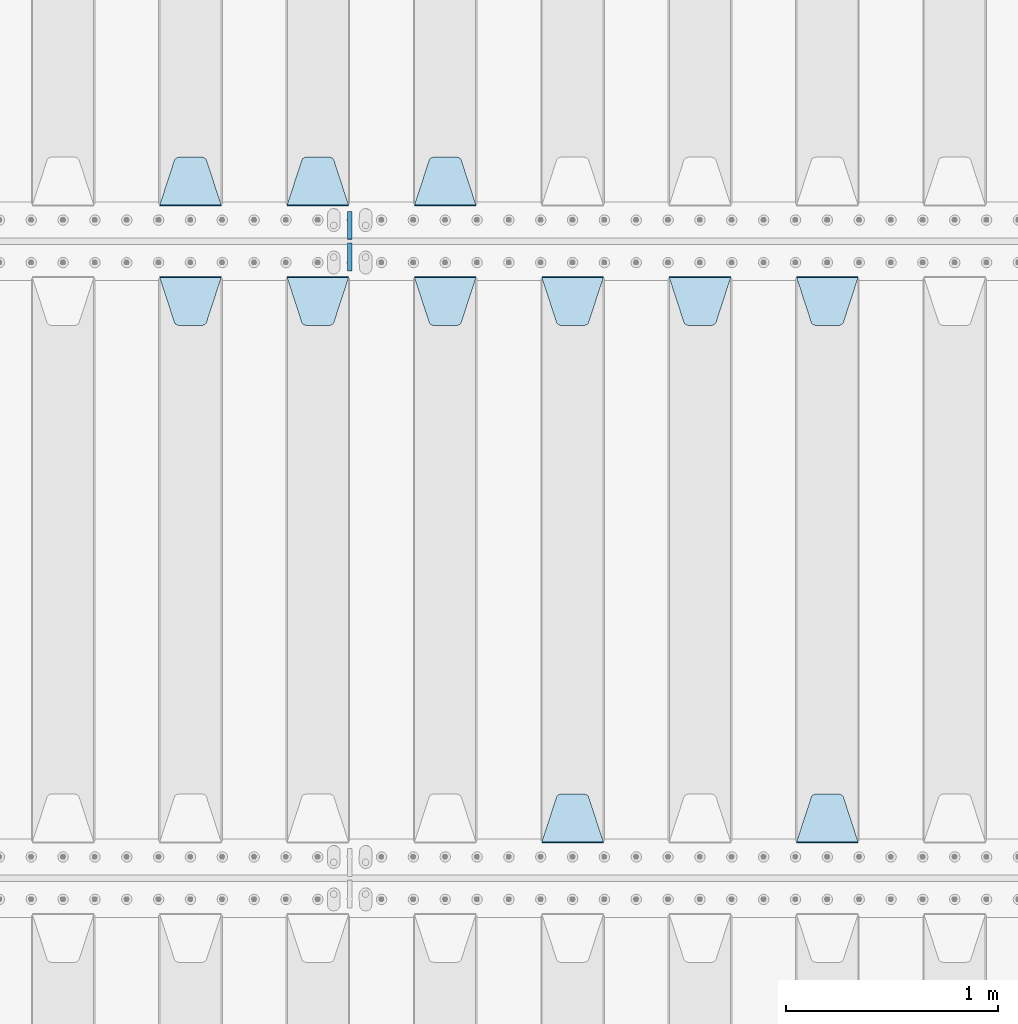
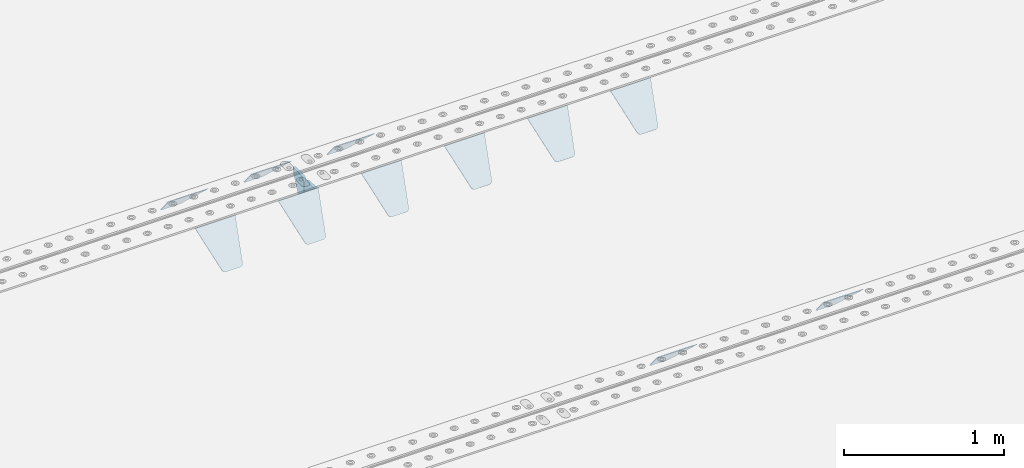
# One storey, part 196 of 240: 13 plates.
"""IFC2X3 building model written with IfcOpenShell, lengths in millimetres."""

from ifc_helpers import new_model, si_unit, frame, origin_with_axes, place, context, subcontext, project, spatial, faceted_brep, material, type_object, element, save


model = new_model("IFC2X3")

# Units and contexts
model_context = context("Model", 3, precision=1e-05, world=origin_with_axes())
body_context = subcontext(model_context, "Body", "Model", "MODEL_VIEW")
ifc_project = project(units=[si_unit("LENGTHUNIT", "METRE", prefix="MILLI"), si_unit("AREAUNIT", "SQUARE_METRE"), si_unit("VOLUMEUNIT", "CUBIC_METRE"), si_unit("MASSUNIT", "GRAM", prefix="KILO"), si_unit("TIMEUNIT", "SECOND"), si_unit("PLANEANGLEUNIT", "RADIAN"), si_unit("SOLIDANGLEUNIT", "STERADIAN"), si_unit("THERMODYNAMICTEMPERATUREUNIT", "DEGREE_CELSIUS"), si_unit("LUMINOUSINTENSITYUNIT", "LUMEN")], contexts=[model_context])

# Site, building, storey
site_placement = place(None, origin_with_axes())
site = spatial("IfcSite", under=ifc_project, at=site_placement, CompositionType="ELEMENT")
building_placement = place(site_placement, origin_with_axes())
building = spatial("IfcBuilding", under=site, at=building_placement, Name="Standard", CompositionType="ELEMENT")
storey_placement = place(building_placement, origin_with_axes())
storey = spatial("IfcBuildingStorey", under=building, at=storey_placement, Name="Undefined", CompositionType="ELEMENT", Elevation=0.0)

# Plates
ifc_material = material(Name="STEEL/S355N")
plate_type_1 = type_object("IfcPlateType", PredefinedType="NOTDEFINED")
plate_1_placement = place(storey_placement, frame((47195.0, 30168.232233047, -1.76776695296758), z_axis=(0.0, 0.707106781186547, -0.707106781186548), x_axis=(-1.0, 0.0, 0.0)))
element("IfcPlate", 1, at=plate_1_placement, inside=storey, type_object=plate_type_1, material=ifc_material, context=body_context, shape_type="Brep", body=[
    faceted_brep([(0.0, -2.5, 0.0), (69.345504679477, -2.50000000000364, 300.171731424827), (69.345504679477, 2.49999999999636, 300.171731424827), (0.0, 2.5, 0.0), (70.927406119954, -2.50000000000364, 304.897442415397), (70.927406119954, 2.49999999999636, 304.897442415397), (73.3818627772271, -2.50000000000728, 309.234538108525), (73.3818627772271, 2.49999999999636, 309.234538108529), (76.6187032999587, -2.50000000000728, 313.023683126099), (76.6187032999587, 2.49999999999636, 313.023683126103), (80.5190132705029, -2.50000000000364, 316.125672595368), (80.5190132705029, 2.49999999999636, 316.125672595368), (84.9395038596849, -2.50000000000364, 318.426546230472), (84.9395038596849, 2.49999999999636, 318.426546230472), (89.7177759439219, -2.5, 319.841774983277), (89.7177759439219, 2.49999999999636, 319.841774983273), (94.6782862926484, -2.50000000000364, 320.319366455074), (94.6782862926484, 2.49999999999636, 320.319366455074), (195.321713707352, -2.50000000000364, 320.319366455074), (195.321713707352, 2.49999999999636, 320.319366455074), (200.282224056078, -2.50000000000364, 319.841774983273), (200.282224056078, 2.49999999999636, 319.841774983273), (205.060496140315, -2.50000000000364, 318.426546230472), (205.060496140315, 2.49999999999636, 318.426546230472), (209.480986729497, -2.50000000000364, 316.125672595368), (209.480986729497, 2.49999999999636, 316.125672595368), (213.381296700041, -2.50000000000728, 313.023683126099), (213.381296700041, 2.49999999999272, 313.023683126099), (216.618137222766, -2.50000000000364, 309.234538108522), (216.618137222766, 2.49999999999636, 309.234538108522), (219.072593880039, -2.50000000000364, 304.897442415397), (219.072593880039, 2.49999999999636, 304.897442415397), (220.654495320523, -2.50000000000364, 300.171731424827), (220.654495320523, 2.49999999999636, 300.171731424827), (290.0, -2.50000000000364, -3.63797880709171e-12), (290.0, 2.49999999999636, -3.63797880709171e-12)], [[[0, 1, 2, 3]], [[1, 4, 5, 2]], [[4, 6, 7, 5]], [[6, 8, 9, 7]], [[8, 10, 11, 9]], [[10, 12, 13, 11]], [[12, 14, 15, 13]], [[14, 16, 17, 15]], [[16, 18, 19, 17]], [[18, 20, 21, 19]], [[20, 22, 23, 21]], [[22, 24, 25, 23]], [[24, 26, 27, 25]], [[26, 28, 29, 27]], [[28, 30, 31, 29]], [[30, 32, 33, 31]], [[32, 34, 35, 33]], [[34, 0, 3, 35]], [[5, 7, 9, 11, 13, 15, 17, 19, 21, 23, 25, 27, 29, 31, 33, 35, 3, 2]], [[34, 32, 30, 28, 26, 24, 22, 20, 18, 16, 14, 12, 10, 8, 6, 4, 1, 0]]]),
])
plate_2_placement = place(storey_placement, frame((46595.0, 30168.232233047, -1.76776695296758), z_axis=(0.0, 0.707106781186547, -0.707106781186548), x_axis=(-1.0, 0.0, 0.0)))
element("IfcPlate", 2, at=plate_2_placement, inside=storey, type_object=plate_type_1, material=ifc_material, context=body_context, shape_type="Brep", body=[
    faceted_brep([(0.0, -2.5, 0.0), (69.345504679477, -2.50000000000364, 300.171731424827), (69.345504679477, 2.49999999999636, 300.171731424827), (0.0, 2.5, 0.0), (70.927406119954, -2.50000000000364, 304.897442415397), (70.927406119954, 2.49999999999636, 304.897442415397), (73.3818627772271, -2.50000000000728, 309.234538108525), (73.3818627772271, 2.49999999999636, 309.234538108529), (76.6187032999587, -2.50000000000728, 313.023683126099), (76.6187032999587, 2.49999999999636, 313.023683126103), (80.5190132705029, -2.50000000000364, 316.125672595368), (80.5190132705029, 2.49999999999636, 316.125672595368), (84.9395038596849, -2.50000000000364, 318.426546230472), (84.9395038596849, 2.49999999999636, 318.426546230472), (89.7177759439219, -2.5, 319.841774983277), (89.7177759439219, 2.49999999999636, 319.841774983273), (94.6782862926484, -2.50000000000364, 320.319366455074), (94.6782862926484, 2.49999999999636, 320.319366455074), (195.321713707352, -2.50000000000364, 320.319366455074), (195.321713707352, 2.49999999999636, 320.319366455074), (200.282224056078, -2.50000000000364, 319.841774983273), (200.282224056078, 2.49999999999636, 319.841774983273), (205.060496140315, -2.50000000000364, 318.426546230472), (205.060496140315, 2.49999999999636, 318.426546230472), (209.480986729497, -2.50000000000364, 316.125672595368), (209.480986729497, 2.49999999999636, 316.125672595368), (213.381296700041, -2.50000000000728, 313.023683126099), (213.381296700041, 2.49999999999272, 313.023683126099), (216.618137222766, -2.50000000000364, 309.234538108522), (216.618137222766, 2.49999999999636, 309.234538108522), (219.072593880039, -2.50000000000364, 304.897442415397), (219.072593880039, 2.49999999999636, 304.897442415397), (220.654495320523, -2.50000000000364, 300.171731424827), (220.654495320523, 2.49999999999636, 300.171731424827), (290.0, -2.50000000000364, -3.63797880709171e-12), (290.0, 2.49999999999636, -3.63797880709171e-12)], [[[0, 1, 2, 3]], [[1, 4, 5, 2]], [[4, 6, 7, 5]], [[6, 8, 9, 7]], [[8, 10, 11, 9]], [[10, 12, 13, 11]], [[12, 14, 15, 13]], [[14, 16, 17, 15]], [[16, 18, 19, 17]], [[18, 20, 21, 19]], [[20, 22, 23, 21]], [[22, 24, 25, 23]], [[24, 26, 27, 25]], [[26, 28, 29, 27]], [[28, 30, 31, 29]], [[30, 32, 33, 31]], [[32, 34, 35, 33]], [[34, 0, 3, 35]], [[5, 7, 9, 11, 13, 15, 17, 19, 21, 23, 25, 27, 29, 31, 33, 35, 3, 2]], [[34, 32, 30, 28, 26, 24, 22, 20, 18, 16, 14, 12, 10, 8, 6, 4, 1, 0]]]),
])
plate_3_placement = place(storey_placement, frame((45995.0, 30168.232233047, -1.76776695296758), z_axis=(0.0, 0.707106781186547, -0.707106781186548), x_axis=(-1.0, 0.0, 0.0)))
element("IfcPlate", 3, at=plate_3_placement, inside=storey, type_object=plate_type_1, material=ifc_material, context=body_context, shape_type="Brep", body=[
    faceted_brep([(0.0, -2.5, 0.0), (69.345504679477, -2.50000000000364, 300.171731424827), (69.345504679477, 2.49999999999636, 300.171731424827), (0.0, 2.5, 0.0), (70.927406119954, -2.50000000000364, 304.897442415397), (70.927406119954, 2.49999999999636, 304.897442415397), (73.3818627772271, -2.50000000000728, 309.234538108525), (73.3818627772271, 2.49999999999636, 309.234538108529), (76.6187032999587, -2.50000000000728, 313.023683126099), (76.6187032999587, 2.49999999999636, 313.023683126103), (80.5190132705029, -2.50000000000364, 316.125672595368), (80.5190132705029, 2.49999999999636, 316.125672595368), (84.9395038596849, -2.50000000000364, 318.426546230472), (84.9395038596849, 2.49999999999636, 318.426546230472), (89.7177759439219, -2.5, 319.841774983277), (89.7177759439219, 2.49999999999636, 319.841774983273), (94.6782862926484, -2.50000000000364, 320.319366455074), (94.6782862926484, 2.49999999999636, 320.319366455074), (195.321713707352, -2.50000000000364, 320.319366455074), (195.321713707352, 2.49999999999636, 320.319366455074), (200.282224056078, -2.50000000000364, 319.841774983273), (200.282224056078, 2.49999999999636, 319.841774983273), (205.060496140315, -2.50000000000364, 318.426546230472), (205.060496140315, 2.49999999999636, 318.426546230472), (209.480986729497, -2.50000000000364, 316.125672595368), (209.480986729497, 2.49999999999636, 316.125672595368), (213.381296700041, -2.50000000000728, 313.023683126099), (213.381296700041, 2.49999999999272, 313.023683126099), (216.618137222766, -2.50000000000364, 309.234538108522), (216.618137222766, 2.49999999999636, 309.234538108522), (219.072593880039, -2.50000000000364, 304.897442415397), (219.072593880039, 2.49999999999636, 304.897442415397), (220.654495320523, -2.50000000000364, 300.171731424827), (220.654495320523, 2.49999999999636, 300.171731424827), (290.0, -2.50000000000364, -3.63797880709171e-12), (290.0, 2.49999999999636, -3.63797880709171e-12)], [[[0, 1, 2, 3]], [[1, 4, 5, 2]], [[4, 6, 7, 5]], [[6, 8, 9, 7]], [[8, 10, 11, 9]], [[10, 12, 13, 11]], [[12, 14, 15, 13]], [[14, 16, 17, 15]], [[16, 18, 19, 17]], [[18, 20, 21, 19]], [[20, 22, 23, 21]], [[22, 24, 25, 23]], [[24, 26, 27, 25]], [[26, 28, 29, 27]], [[28, 30, 31, 29]], [[30, 32, 33, 31]], [[32, 34, 35, 33]], [[34, 0, 3, 35]], [[5, 7, 9, 11, 13, 15, 17, 19, 21, 23, 25, 27, 29, 31, 33, 35, 3, 2]], [[34, 32, 30, 28, 26, 24, 22, 20, 18, 16, 14, 12, 10, 8, 6, 4, 1, 0]]]),
])
plate_4_placement = place(storey_placement, frame((48705.0, 29831.767766956, -1.76776695296758), z_axis=(0.0, -0.707106781186547, -0.707106781186548), x_axis=(1.0, 0.0, 0.0)))
element("IfcPlate", 4, at=plate_4_placement, inside=storey, type_object=plate_type_1, material=ifc_material, context=body_context, shape_type="Brep", body=[
    faceted_brep([(0.0, -2.5, 0.0), (69.345504679477, -2.50000000000364, 300.171731424827), (69.345504679477, 2.49999999999636, 300.171731424827), (0.0, 2.5, 0.0), (70.927406119954, -2.50000000000364, 304.897442415397), (70.927406119954, 2.49999999999636, 304.897442415397), (73.3818627772271, -2.50000000000728, 309.234538108525), (73.3818627772271, 2.49999999999636, 309.234538108529), (76.6187032999587, -2.50000000000728, 313.023683126099), (76.6187032999587, 2.49999999999636, 313.023683126103), (80.5190132705029, -2.50000000000364, 316.125672595368), (80.5190132705029, 2.49999999999636, 316.125672595368), (84.9395038596849, -2.50000000000364, 318.426546230472), (84.9395038596849, 2.49999999999636, 318.426546230472), (89.7177759439219, -2.5, 319.841774983277), (89.7177759439219, 2.49999999999636, 319.841774983273), (94.6782862926484, -2.50000000000364, 320.319366455074), (94.6782862926484, 2.49999999999636, 320.319366455074), (195.321713707352, -2.50000000000364, 320.319366455074), (195.321713707352, 2.49999999999636, 320.319366455074), (200.282224056078, -2.50000000000364, 319.841774983273), (200.282224056078, 2.49999999999636, 319.841774983273), (205.060496140315, -2.50000000000364, 318.426546230472), (205.060496140315, 2.49999999999636, 318.426546230472), (209.480986729497, -2.50000000000364, 316.125672595368), (209.480986729497, 2.49999999999636, 316.125672595368), (213.381296700041, -2.50000000000728, 313.023683126099), (213.381296700041, 2.49999999999272, 313.023683126099), (216.618137222766, -2.50000000000364, 309.234538108522), (216.618137222766, 2.49999999999636, 309.234538108522), (219.072593880039, -2.50000000000364, 304.897442415397), (219.072593880039, 2.49999999999636, 304.897442415397), (220.654495320523, -2.50000000000364, 300.171731424827), (220.654495320523, 2.49999999999636, 300.171731424827), (290.0, -2.50000000000364, -3.63797880709171e-12), (290.0, 2.49999999999636, -3.63797880709171e-12)], [[[0, 1, 2, 3]], [[1, 4, 5, 2]], [[4, 6, 7, 5]], [[6, 8, 9, 7]], [[8, 10, 11, 9]], [[10, 12, 13, 11]], [[12, 14, 15, 13]], [[14, 16, 17, 15]], [[16, 18, 19, 17]], [[18, 20, 21, 19]], [[20, 22, 23, 21]], [[22, 24, 25, 23]], [[24, 26, 27, 25]], [[26, 28, 29, 27]], [[28, 30, 31, 29]], [[30, 32, 33, 31]], [[32, 34, 35, 33]], [[34, 0, 3, 35]], [[5, 7, 9, 11, 13, 15, 17, 19, 21, 23, 25, 27, 29, 31, 33, 35, 3, 2]], [[34, 32, 30, 28, 26, 24, 22, 20, 18, 16, 14, 12, 10, 8, 6, 4, 1, 0]]]),
])
plate_5_placement = place(storey_placement, frame((48995.0, 27168.232233047, -1.76776695296758), z_axis=(0.0, 0.707106781186547, -0.707106781186548), x_axis=(-1.0, 0.0, 0.0)))
element("IfcPlate", 5, at=plate_5_placement, inside=storey, type_object=plate_type_1, material=ifc_material, context=body_context, shape_type="Brep", body=[
    faceted_brep([(0.0, -2.5, 0.0), (69.345504679477, -2.50000000000364, 300.171731424827), (69.345504679477, 2.49999999999636, 300.171731424827), (0.0, 2.5, 0.0), (70.927406119954, -2.50000000000364, 304.897442415397), (70.927406119954, 2.49999999999636, 304.897442415397), (73.3818627772271, -2.50000000000728, 309.234538108525), (73.3818627772271, 2.49999999999636, 309.234538108529), (76.6187032999587, -2.50000000000728, 313.023683126099), (76.6187032999587, 2.49999999999636, 313.023683126103), (80.5190132705029, -2.50000000000364, 316.125672595368), (80.5190132705029, 2.49999999999636, 316.125672595368), (84.9395038596849, -2.50000000000364, 318.426546230472), (84.9395038596849, 2.49999999999636, 318.426546230472), (89.7177759439219, -2.5, 319.841774983277), (89.7177759439219, 2.49999999999636, 319.841774983273), (94.6782862926484, -2.50000000000364, 320.319366455074), (94.6782862926484, 2.49999999999636, 320.319366455074), (195.321713707352, -2.50000000000364, 320.319366455074), (195.321713707352, 2.49999999999636, 320.319366455074), (200.282224056078, -2.50000000000364, 319.841774983273), (200.282224056078, 2.49999999999636, 319.841774983273), (205.060496140315, -2.50000000000364, 318.426546230472), (205.060496140315, 2.49999999999636, 318.426546230472), (209.480986729497, -2.50000000000364, 316.125672595368), (209.480986729497, 2.49999999999636, 316.125672595368), (213.381296700041, -2.50000000000728, 313.023683126099), (213.381296700041, 2.49999999999272, 313.023683126099), (216.618137222766, -2.50000000000364, 309.234538108522), (216.618137222766, 2.49999999999636, 309.234538108522), (219.072593880039, -2.50000000000364, 304.897442415397), (219.072593880039, 2.49999999999636, 304.897442415397), (220.654495320523, -2.50000000000364, 300.171731424827), (220.654495320523, 2.49999999999636, 300.171731424827), (290.0, -2.50000000000364, -3.63797880709171e-12), (290.0, 2.49999999999636, -3.63797880709171e-12)], [[[0, 1, 2, 3]], [[1, 4, 5, 2]], [[4, 6, 7, 5]], [[6, 8, 9, 7]], [[8, 10, 11, 9]], [[10, 12, 13, 11]], [[12, 14, 15, 13]], [[14, 16, 17, 15]], [[16, 18, 19, 17]], [[18, 20, 21, 19]], [[20, 22, 23, 21]], [[22, 24, 25, 23]], [[24, 26, 27, 25]], [[26, 28, 29, 27]], [[28, 30, 31, 29]], [[30, 32, 33, 31]], [[32, 34, 35, 33]], [[34, 0, 3, 35]], [[5, 7, 9, 11, 13, 15, 17, 19, 21, 23, 25, 27, 29, 31, 33, 35, 3, 2]], [[34, 32, 30, 28, 26, 24, 22, 20, 18, 16, 14, 12, 10, 8, 6, 4, 1, 0]]]),
])
plate_6_placement = place(storey_placement, frame((48105.0, 29831.767766956, -1.76776695296758), z_axis=(0.0, -0.707106781186547, -0.707106781186548), x_axis=(1.0, 0.0, 0.0)))
element("IfcPlate", 6, at=plate_6_placement, inside=storey, type_object=plate_type_1, material=ifc_material, context=body_context, shape_type="Brep", body=[
    faceted_brep([(0.0, -2.5, 0.0), (69.345504679477, -2.50000000000364, 300.171731424827), (69.345504679477, 2.49999999999636, 300.171731424827), (0.0, 2.5, 0.0), (70.927406119954, -2.50000000000364, 304.897442415397), (70.927406119954, 2.49999999999636, 304.897442415397), (73.3818627772271, -2.50000000000728, 309.234538108525), (73.3818627772271, 2.49999999999636, 309.234538108529), (76.6187032999587, -2.50000000000728, 313.023683126099), (76.6187032999587, 2.49999999999636, 313.023683126103), (80.5190132705029, -2.50000000000364, 316.125672595368), (80.5190132705029, 2.49999999999636, 316.125672595368), (84.9395038596849, -2.50000000000364, 318.426546230472), (84.9395038596849, 2.49999999999636, 318.426546230472), (89.7177759439219, -2.5, 319.841774983277), (89.7177759439219, 2.49999999999636, 319.841774983273), (94.6782862926484, -2.50000000000364, 320.319366455074), (94.6782862926484, 2.49999999999636, 320.319366455074), (195.321713707352, -2.50000000000364, 320.319366455074), (195.321713707352, 2.49999999999636, 320.319366455074), (200.282224056078, -2.50000000000364, 319.841774983273), (200.282224056078, 2.49999999999636, 319.841774983273), (205.060496140315, -2.50000000000364, 318.426546230472), (205.060496140315, 2.49999999999636, 318.426546230472), (209.480986729497, -2.50000000000364, 316.125672595368), (209.480986729497, 2.49999999999636, 316.125672595368), (213.381296700041, -2.50000000000728, 313.023683126099), (213.381296700041, 2.49999999999272, 313.023683126099), (216.618137222766, -2.50000000000364, 309.234538108522), (216.618137222766, 2.49999999999636, 309.234538108522), (219.072593880039, -2.50000000000364, 304.897442415397), (219.072593880039, 2.49999999999636, 304.897442415397), (220.654495320523, -2.50000000000364, 300.171731424827), (220.654495320523, 2.49999999999636, 300.171731424827), (290.0, -2.50000000000364, -3.63797880709171e-12), (290.0, 2.49999999999636, -3.63797880709171e-12)], [[[0, 1, 2, 3]], [[1, 4, 5, 2]], [[4, 6, 7, 5]], [[6, 8, 9, 7]], [[8, 10, 11, 9]], [[10, 12, 13, 11]], [[12, 14, 15, 13]], [[14, 16, 17, 15]], [[16, 18, 19, 17]], [[18, 20, 21, 19]], [[20, 22, 23, 21]], [[22, 24, 25, 23]], [[24, 26, 27, 25]], [[26, 28, 29, 27]], [[28, 30, 31, 29]], [[30, 32, 33, 31]], [[32, 34, 35, 33]], [[34, 0, 3, 35]], [[5, 7, 9, 11, 13, 15, 17, 19, 21, 23, 25, 27, 29, 31, 33, 35, 3, 2]], [[34, 32, 30, 28, 26, 24, 22, 20, 18, 16, 14, 12, 10, 8, 6, 4, 1, 0]]]),
])
plate_7_placement = place(storey_placement, frame((47505.0, 29831.767766956, -1.76776695296758), z_axis=(0.0, -0.707106781186547, -0.707106781186548), x_axis=(1.0, 0.0, 0.0)))
element("IfcPlate", 7, at=plate_7_placement, inside=storey, type_object=plate_type_1, material=ifc_material, context=body_context, shape_type="Brep", body=[
    faceted_brep([(0.0, -2.5, 0.0), (69.345504679477, -2.50000000000364, 300.171731424827), (69.345504679477, 2.49999999999636, 300.171731424827), (0.0, 2.5, 0.0), (70.927406119954, -2.50000000000364, 304.897442415397), (70.927406119954, 2.49999999999636, 304.897442415397), (73.3818627772271, -2.50000000000728, 309.234538108525), (73.3818627772271, 2.49999999999636, 309.234538108529), (76.6187032999587, -2.50000000000728, 313.023683126099), (76.6187032999587, 2.49999999999636, 313.023683126103), (80.5190132705029, -2.50000000000364, 316.125672595368), (80.5190132705029, 2.49999999999636, 316.125672595368), (84.9395038596849, -2.50000000000364, 318.426546230472), (84.9395038596849, 2.49999999999636, 318.426546230472), (89.7177759439219, -2.5, 319.841774983277), (89.7177759439219, 2.49999999999636, 319.841774983273), (94.6782862926484, -2.50000000000364, 320.319366455074), (94.6782862926484, 2.49999999999636, 320.319366455074), (195.321713707352, -2.50000000000364, 320.319366455074), (195.321713707352, 2.49999999999636, 320.319366455074), (200.282224056078, -2.50000000000364, 319.841774983273), (200.282224056078, 2.49999999999636, 319.841774983273), (205.060496140315, -2.50000000000364, 318.426546230472), (205.060496140315, 2.49999999999636, 318.426546230472), (209.480986729497, -2.50000000000364, 316.125672595368), (209.480986729497, 2.49999999999636, 316.125672595368), (213.381296700041, -2.50000000000728, 313.023683126099), (213.381296700041, 2.49999999999272, 313.023683126099), (216.618137222766, -2.50000000000364, 309.234538108522), (216.618137222766, 2.49999999999636, 309.234538108522), (219.072593880039, -2.50000000000364, 304.897442415397), (219.072593880039, 2.49999999999636, 304.897442415397), (220.654495320523, -2.50000000000364, 300.171731424827), (220.654495320523, 2.49999999999636, 300.171731424827), (290.0, -2.50000000000364, -3.63797880709171e-12), (290.0, 2.49999999999636, -3.63797880709171e-12)], [[[0, 1, 2, 3]], [[1, 4, 5, 2]], [[4, 6, 7, 5]], [[6, 8, 9, 7]], [[8, 10, 11, 9]], [[10, 12, 13, 11]], [[12, 14, 15, 13]], [[14, 16, 17, 15]], [[16, 18, 19, 17]], [[18, 20, 21, 19]], [[20, 22, 23, 21]], [[22, 24, 25, 23]], [[24, 26, 27, 25]], [[26, 28, 29, 27]], [[28, 30, 31, 29]], [[30, 32, 33, 31]], [[32, 34, 35, 33]], [[34, 0, 3, 35]], [[5, 7, 9, 11, 13, 15, 17, 19, 21, 23, 25, 27, 29, 31, 33, 35, 3, 2]], [[34, 32, 30, 28, 26, 24, 22, 20, 18, 16, 14, 12, 10, 8, 6, 4, 1, 0]]]),
])
plate_8_placement = place(storey_placement, frame((47795.0, 27168.232233047, -1.76776695296758), z_axis=(0.0, 0.707106781186547, -0.707106781186548), x_axis=(-1.0, 0.0, 0.0)))
element("IfcPlate", 8, at=plate_8_placement, inside=storey, type_object=plate_type_1, material=ifc_material, context=body_context, shape_type="Brep", body=[
    faceted_brep([(0.0, -2.5, 0.0), (69.345504679477, -2.50000000000364, 300.171731424827), (69.345504679477, 2.49999999999636, 300.171731424827), (0.0, 2.5, 0.0), (70.927406119954, -2.50000000000364, 304.897442415397), (70.927406119954, 2.49999999999636, 304.897442415397), (73.3818627772271, -2.50000000000728, 309.234538108525), (73.3818627772271, 2.49999999999636, 309.234538108529), (76.6187032999587, -2.50000000000728, 313.023683126099), (76.6187032999587, 2.49999999999636, 313.023683126103), (80.5190132705029, -2.50000000000364, 316.125672595368), (80.5190132705029, 2.49999999999636, 316.125672595368), (84.9395038596849, -2.50000000000364, 318.426546230472), (84.9395038596849, 2.49999999999636, 318.426546230472), (89.7177759439219, -2.5, 319.841774983277), (89.7177759439219, 2.49999999999636, 319.841774983273), (94.6782862926484, -2.50000000000364, 320.319366455074), (94.6782862926484, 2.49999999999636, 320.319366455074), (195.321713707352, -2.50000000000364, 320.319366455074), (195.321713707352, 2.49999999999636, 320.319366455074), (200.282224056078, -2.50000000000364, 319.841774983273), (200.282224056078, 2.49999999999636, 319.841774983273), (205.060496140315, -2.50000000000364, 318.426546230472), (205.060496140315, 2.49999999999636, 318.426546230472), (209.480986729497, -2.50000000000364, 316.125672595368), (209.480986729497, 2.49999999999636, 316.125672595368), (213.381296700041, -2.50000000000728, 313.023683126099), (213.381296700041, 2.49999999999272, 313.023683126099), (216.618137222766, -2.50000000000364, 309.234538108522), (216.618137222766, 2.49999999999636, 309.234538108522), (219.072593880039, -2.50000000000364, 304.897442415397), (219.072593880039, 2.49999999999636, 304.897442415397), (220.654495320523, -2.50000000000364, 300.171731424827), (220.654495320523, 2.49999999999636, 300.171731424827), (290.0, -2.50000000000364, -3.63797880709171e-12), (290.0, 2.49999999999636, -3.63797880709171e-12)], [[[0, 1, 2, 3]], [[1, 4, 5, 2]], [[4, 6, 7, 5]], [[6, 8, 9, 7]], [[8, 10, 11, 9]], [[10, 12, 13, 11]], [[12, 14, 15, 13]], [[14, 16, 17, 15]], [[16, 18, 19, 17]], [[18, 20, 21, 19]], [[20, 22, 23, 21]], [[22, 24, 25, 23]], [[24, 26, 27, 25]], [[26, 28, 29, 27]], [[28, 30, 31, 29]], [[30, 32, 33, 31]], [[32, 34, 35, 33]], [[34, 0, 3, 35]], [[5, 7, 9, 11, 13, 15, 17, 19, 21, 23, 25, 27, 29, 31, 33, 35, 3, 2]], [[34, 32, 30, 28, 26, 24, 22, 20, 18, 16, 14, 12, 10, 8, 6, 4, 1, 0]]]),
])
plate_9_placement = place(storey_placement, frame((46905.0, 29831.767766956, -1.76776695296758), z_axis=(0.0, -0.707106781186547, -0.707106781186548), x_axis=(1.0, 0.0, 0.0)))
element("IfcPlate", 9, at=plate_9_placement, inside=storey, type_object=plate_type_1, material=ifc_material, context=body_context, shape_type="Brep", body=[
    faceted_brep([(0.0, -2.5, 0.0), (69.345504679477, -2.50000000000364, 300.171731424827), (69.345504679477, 2.49999999999636, 300.171731424827), (0.0, 2.5, 0.0), (70.927406119954, -2.50000000000364, 304.897442415397), (70.927406119954, 2.49999999999636, 304.897442415397), (73.3818627772271, -2.50000000000728, 309.234538108525), (73.3818627772271, 2.49999999999636, 309.234538108529), (76.6187032999587, -2.50000000000728, 313.023683126099), (76.6187032999587, 2.49999999999636, 313.023683126103), (80.5190132705029, -2.50000000000364, 316.125672595368), (80.5190132705029, 2.49999999999636, 316.125672595368), (84.9395038596849, -2.50000000000364, 318.426546230472), (84.9395038596849, 2.49999999999636, 318.426546230472), (89.7177759439219, -2.5, 319.841774983277), (89.7177759439219, 2.49999999999636, 319.841774983273), (94.6782862926484, -2.50000000000364, 320.319366455074), (94.6782862926484, 2.49999999999636, 320.319366455074), (195.321713707352, -2.50000000000364, 320.319366455074), (195.321713707352, 2.49999999999636, 320.319366455074), (200.282224056078, -2.50000000000364, 319.841774983273), (200.282224056078, 2.49999999999636, 319.841774983273), (205.060496140315, -2.50000000000364, 318.426546230472), (205.060496140315, 2.49999999999636, 318.426546230472), (209.480986729497, -2.50000000000364, 316.125672595368), (209.480986729497, 2.49999999999636, 316.125672595368), (213.381296700041, -2.50000000000728, 313.023683126099), (213.381296700041, 2.49999999999272, 313.023683126099), (216.618137222766, -2.50000000000364, 309.234538108522), (216.618137222766, 2.49999999999636, 309.234538108522), (219.072593880039, -2.50000000000364, 304.897442415397), (219.072593880039, 2.49999999999636, 304.897442415397), (220.654495320523, -2.50000000000364, 300.171731424827), (220.654495320523, 2.49999999999636, 300.171731424827), (290.0, -2.50000000000364, -3.63797880709171e-12), (290.0, 2.49999999999636, -3.63797880709171e-12)], [[[0, 1, 2, 3]], [[1, 4, 5, 2]], [[4, 6, 7, 5]], [[6, 8, 9, 7]], [[8, 10, 11, 9]], [[10, 12, 13, 11]], [[12, 14, 15, 13]], [[14, 16, 17, 15]], [[16, 18, 19, 17]], [[18, 20, 21, 19]], [[20, 22, 23, 21]], [[22, 24, 25, 23]], [[24, 26, 27, 25]], [[26, 28, 29, 27]], [[28, 30, 31, 29]], [[30, 32, 33, 31]], [[32, 34, 35, 33]], [[34, 0, 3, 35]], [[5, 7, 9, 11, 13, 15, 17, 19, 21, 23, 25, 27, 29, 31, 33, 35, 3, 2]], [[34, 32, 30, 28, 26, 24, 22, 20, 18, 16, 14, 12, 10, 8, 6, 4, 1, 0]]]),
])
plate_10_placement = place(storey_placement, frame((46305.0, 29831.767766956, -1.76776695296758), z_axis=(0.0, -0.707106781186547, -0.707106781186548), x_axis=(1.0, 0.0, 0.0)))
element("IfcPlate", 10, at=plate_10_placement, inside=storey, type_object=plate_type_1, material=ifc_material, context=body_context, shape_type="Brep", body=[
    faceted_brep([(0.0, -2.5, 0.0), (69.345504679477, -2.50000000000364, 300.171731424827), (69.345504679477, 2.49999999999636, 300.171731424827), (0.0, 2.5, 0.0), (70.927406119954, -2.50000000000364, 304.897442415397), (70.927406119954, 2.49999999999636, 304.897442415397), (73.3818627772271, -2.50000000000728, 309.234538108525), (73.3818627772271, 2.49999999999636, 309.234538108529), (76.6187032999587, -2.50000000000728, 313.023683126099), (76.6187032999587, 2.49999999999636, 313.023683126103), (80.5190132705029, -2.50000000000364, 316.125672595368), (80.5190132705029, 2.49999999999636, 316.125672595368), (84.9395038596849, -2.50000000000364, 318.426546230472), (84.9395038596849, 2.49999999999636, 318.426546230472), (89.7177759439219, -2.5, 319.841774983277), (89.7177759439219, 2.49999999999636, 319.841774983273), (94.6782862926484, -2.50000000000364, 320.319366455074), (94.6782862926484, 2.49999999999636, 320.319366455074), (195.321713707352, -2.50000000000364, 320.319366455074), (195.321713707352, 2.49999999999636, 320.319366455074), (200.282224056078, -2.50000000000364, 319.841774983273), (200.282224056078, 2.49999999999636, 319.841774983273), (205.060496140315, -2.50000000000364, 318.426546230472), (205.060496140315, 2.49999999999636, 318.426546230472), (209.480986729497, -2.50000000000364, 316.125672595368), (209.480986729497, 2.49999999999636, 316.125672595368), (213.381296700041, -2.50000000000728, 313.023683126099), (213.381296700041, 2.49999999999272, 313.023683126099), (216.618137222766, -2.50000000000364, 309.234538108522), (216.618137222766, 2.49999999999636, 309.234538108522), (219.072593880039, -2.50000000000364, 304.897442415397), (219.072593880039, 2.49999999999636, 304.897442415397), (220.654495320523, -2.50000000000364, 300.171731424827), (220.654495320523, 2.49999999999636, 300.171731424827), (290.0, -2.50000000000364, -3.63797880709171e-12), (290.0, 2.49999999999636, -3.63797880709171e-12)], [[[0, 1, 2, 3]], [[1, 4, 5, 2]], [[4, 6, 7, 5]], [[6, 8, 9, 7]], [[8, 10, 11, 9]], [[10, 12, 13, 11]], [[12, 14, 15, 13]], [[14, 16, 17, 15]], [[16, 18, 19, 17]], [[18, 20, 21, 19]], [[20, 22, 23, 21]], [[22, 24, 25, 23]], [[24, 26, 27, 25]], [[26, 28, 29, 27]], [[28, 30, 31, 29]], [[30, 32, 33, 31]], [[32, 34, 35, 33]], [[34, 0, 3, 35]], [[5, 7, 9, 11, 13, 15, 17, 19, 21, 23, 25, 27, 29, 31, 33, 35, 3, 2]], [[34, 32, 30, 28, 26, 24, 22, 20, 18, 16, 14, 12, 10, 8, 6, 4, 1, 0]]]),
])
plate_11_placement = place(storey_placement, frame((45705.0, 29831.767766956, -1.76776695296758), z_axis=(0.0, -0.707106781186547, -0.707106781186548), x_axis=(1.0, 0.0, 0.0)))
element("IfcPlate", 11, at=plate_11_placement, inside=storey, type_object=plate_type_1, material=ifc_material, context=body_context, shape_type="Brep", body=[
    faceted_brep([(0.0, -2.5, 0.0), (69.345504679477, -2.50000000000364, 300.171731424827), (69.345504679477, 2.49999999999636, 300.171731424827), (0.0, 2.5, 0.0), (70.927406119954, -2.50000000000364, 304.897442415397), (70.927406119954, 2.49999999999636, 304.897442415397), (73.3818627772271, -2.50000000000728, 309.234538108525), (73.3818627772271, 2.49999999999636, 309.234538108529), (76.6187032999587, -2.50000000000728, 313.023683126099), (76.6187032999587, 2.49999999999636, 313.023683126103), (80.5190132705029, -2.50000000000364, 316.125672595368), (80.5190132705029, 2.49999999999636, 316.125672595368), (84.9395038596849, -2.50000000000364, 318.426546230472), (84.9395038596849, 2.49999999999636, 318.426546230472), (89.7177759439219, -2.5, 319.841774983277), (89.7177759439219, 2.49999999999636, 319.841774983273), (94.6782862926484, -2.50000000000364, 320.319366455074), (94.6782862926484, 2.49999999999636, 320.319366455074), (195.321713707352, -2.50000000000364, 320.319366455074), (195.321713707352, 2.49999999999636, 320.319366455074), (200.282224056078, -2.50000000000364, 319.841774983273), (200.282224056078, 2.49999999999636, 319.841774983273), (205.060496140315, -2.50000000000364, 318.426546230472), (205.060496140315, 2.49999999999636, 318.426546230472), (209.480986729497, -2.50000000000364, 316.125672595368), (209.480986729497, 2.49999999999636, 316.125672595368), (213.381296700041, -2.50000000000728, 313.023683126099), (213.381296700041, 2.49999999999272, 313.023683126099), (216.618137222766, -2.50000000000364, 309.234538108522), (216.618137222766, 2.49999999999636, 309.234538108522), (219.072593880039, -2.50000000000364, 304.897442415397), (219.072593880039, 2.49999999999636, 304.897442415397), (220.654495320523, -2.50000000000364, 300.171731424827), (220.654495320523, 2.49999999999636, 300.171731424827), (290.0, -2.50000000000364, -3.63797880709171e-12), (290.0, 2.49999999999636, -3.63797880709171e-12)], [[[0, 1, 2, 3]], [[1, 4, 5, 2]], [[4, 6, 7, 5]], [[6, 8, 9, 7]], [[8, 10, 11, 9]], [[10, 12, 13, 11]], [[12, 14, 15, 13]], [[14, 16, 17, 15]], [[16, 18, 19, 17]], [[18, 20, 21, 19]], [[20, 22, 23, 21]], [[22, 24, 25, 23]], [[24, 26, 27, 25]], [[26, 28, 29, 27]], [[28, 30, 31, 29]], [[30, 32, 33, 31]], [[32, 34, 35, 33]], [[34, 0, 3, 35]], [[5, 7, 9, 11, 13, 15, 17, 19, 21, 23, 25, 27, 29, 31, 33, 35, 3, 2]], [[34, 32, 30, 28, 26, 24, 22, 20, 18, 16, 14, 12, 10, 8, 6, 4, 1, 0]]]),
])
plate_type_2 = type_object("IfcPlateType", PredefinedType="NOTDEFINED")
for number, where, z_axis, x_axis in (
    (12, (46600.0, 29860.0, -30.0), (0.0, 0.0, -1.0), (0.0, 1.0, 0.0)),
    (13, (46600.0, 30140.0, -30.0), (0.0, 0.0, -1.0), (0.0, -1.0, 0.0)),
):
    element("IfcPlate", number, at=place(storey_placement, frame(where, z_axis=z_axis, x_axis=x_axis)), inside=storey, type_object=plate_type_2, material=ifc_material, context=body_context, shape_type="Brep", body=[
        faceted_brep([(0.0, -10.0, 0.0), (0.0, -10.0, 30.0), (0.0, 10.0, 30.0), (0.0, 10.0, 0.0), (102.0, -10.0, 250.0), (102.0, 10.0, 250.0), (132.0, -10.0, 250.0), (132.0, 10.0, 250.0), (132.0, -10.0, 30.0), (132.0, 10.0, 30.0), (131.544232590368, -10.0, 24.790554669992), (131.544232590368, 10.0, 24.790554669992), (130.190778623579, -10.0, 19.7393957002299), (130.190778623579, 10.0, 19.7393957002299), (127.980762113533, -10.0, 15.0), (127.980762113533, 10.0, 15.0), (124.98133329357, -10.0, 10.7163717094038), (124.98133329357, 10.0, 10.7163717094038), (121.283628290596, -10.0, 7.01866670643062), (121.283628290596, 10.0, 7.01866670643062), (117.0, -10.0, 4.01923788646684), (117.0, 10.0, 4.01923788646684), (112.260604299769, -10.0, 1.80922137642278), (112.260604299769, 10.0, 1.80922137642278), (107.209445330009, -10.0, 0.455767409633722), (107.209445330009, 10.0, 0.455767409633722), (102.0, -10.0, 0.0), (102.0, 10.0, 0.0)], [[[0, 1, 2, 3]], [[1, 4, 5, 2]], [[4, 6, 7, 5]], [[6, 8, 9, 7]], [[8, 10, 11, 9]], [[10, 12, 13, 11]], [[12, 14, 15, 13]], [[14, 16, 17, 15]], [[16, 18, 19, 17]], [[18, 20, 21, 19]], [[20, 22, 23, 21]], [[22, 24, 25, 23]], [[24, 26, 27, 25]], [[26, 0, 3, 27]], [[5, 7, 9, 11, 13, 15, 17, 19, 21, 23, 25, 27, 3, 2]], [[26, 24, 22, 20, 18, 16, 14, 12, 10, 8, 6, 4, 1, 0]]]),
    ])

save(model, "model.ifc")
